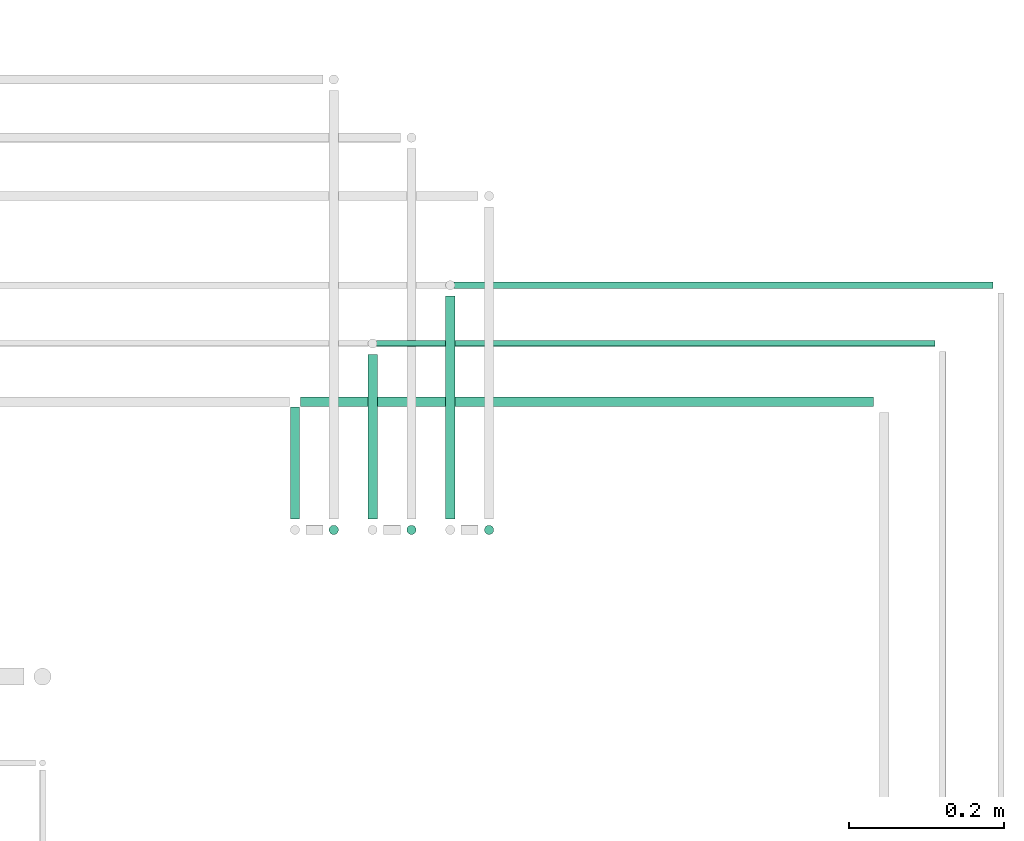
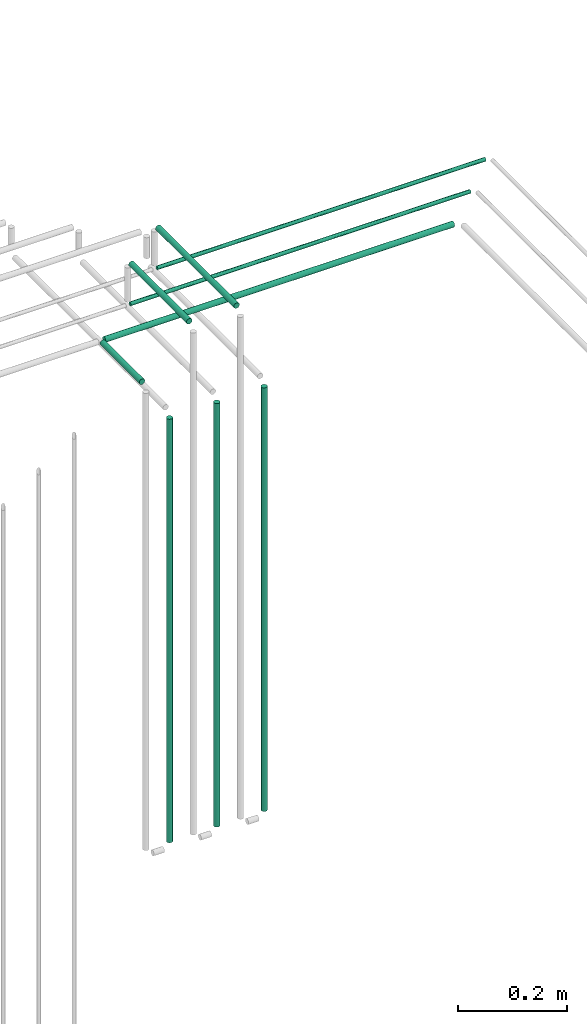
# One storey, part 237 of 331: 9 flow segments.
"""IFC2X3 building model written with IfcOpenShell, lengths in millimetres."""

from ifc_helpers import new_model, entity, si_unit, converted_unit, derived_unit, direction, frame, frame_2d, origin, origin_2d_with_axis, place, context, subcontext, project, spatial, circle, extrude, type_object, element, save


model = new_model("IFC2X3")

# Units and contexts
model_context = context("Model", 3, precision=0.01, world=origin(), true_north=direction((6.12303176911189e-17, 1.0)))
body_context = subcontext(model_context, "Body", "Model", "MODEL_VIEW")
ifc_project = project(units=[si_unit("LENGTHUNIT", "METRE", prefix="MILLI"), si_unit("AREAUNIT", "SQUARE_METRE"), si_unit("VOLUMEUNIT", "CUBIC_METRE"), converted_unit("PLANEANGLEUNIT", "DEGREE", entity("IfcRatioMeasure", 0.0174532925199433), si_unit("PLANEANGLEUNIT", "RADIAN"), dimensions=[0, 0, 0, 0, 0, 0, 0]), si_unit("MASSUNIT", "GRAM", prefix="KILO"), derived_unit("MASSDENSITYUNIT", [(si_unit("MASSUNIT", "GRAM", prefix="KILO"), 1), (si_unit("LENGTHUNIT", "METRE"), -3)]), derived_unit("MOMENTOFINERTIAUNIT", [(si_unit("LENGTHUNIT", "METRE"), 4)]), si_unit("TIMEUNIT", "SECOND"), si_unit("FREQUENCYUNIT", "HERTZ"), si_unit("THERMODYNAMICTEMPERATUREUNIT", "DEGREE_CELSIUS"), derived_unit("THERMALTRANSMITTANCEUNIT", [(si_unit("MASSUNIT", "GRAM", prefix="KILO"), 1), (si_unit("THERMODYNAMICTEMPERATUREUNIT", "KELVIN"), -1), (si_unit("TIMEUNIT", "SECOND"), -3)]), derived_unit("VOLUMETRICFLOWRATEUNIT", [(si_unit("LENGTHUNIT", "METRE"), 3), (si_unit("TIMEUNIT", "SECOND"), -1)]), derived_unit("MASSFLOWRATEUNIT", [(si_unit("MASSUNIT", "GRAM", prefix="KILO"), 1), (si_unit("TIMEUNIT", "SECOND"), -1)]), derived_unit("ROTATIONALFREQUENCYUNIT", [(si_unit("TIMEUNIT", "SECOND"), -1)]), si_unit("ELECTRICCURRENTUNIT", "AMPERE"), si_unit("ELECTRICVOLTAGEUNIT", "VOLT"), si_unit("POWERUNIT", "WATT"), si_unit("FORCEUNIT", "NEWTON", prefix="KILO"), si_unit("ILLUMINANCEUNIT", "LUX"), si_unit("LUMINOUSFLUXUNIT", "LUMEN"), si_unit("LUMINOUSINTENSITYUNIT", "CANDELA"), derived_unit("USERDEFINED", [(si_unit("MASSUNIT", "GRAM", prefix="KILO"), -1), (si_unit("LENGTHUNIT", "METRE"), -2), (si_unit("TIMEUNIT", "SECOND"), 3), (si_unit("LUMINOUSFLUXUNIT", "LUMEN"), 1)]), derived_unit("LINEARVELOCITYUNIT", [(si_unit("LENGTHUNIT", "METRE"), 1), (si_unit("TIMEUNIT", "SECOND"), -1)]), si_unit("PRESSUREUNIT", "PASCAL"), derived_unit("USERDEFINED", [(si_unit("LENGTHUNIT", "METRE"), -2), (si_unit("MASSUNIT", "GRAM", prefix="KILO"), 1), (si_unit("TIMEUNIT", "SECOND"), -2)]), derived_unit("LINEARFORCEUNIT", [(si_unit("MASSUNIT", "GRAM", prefix="KILO"), 1), (si_unit("LENGTHUNIT", "METRE"), 1), (si_unit("TIMEUNIT", "SECOND"), -2), (si_unit("LENGTHUNIT", "METRE"), -1)]), derived_unit("PLANARFORCEUNIT", [(si_unit("MASSUNIT", "GRAM", prefix="KILO"), 1), (si_unit("LENGTHUNIT", "METRE"), 1), (si_unit("TIMEUNIT", "SECOND"), -2), (si_unit("LENGTHUNIT", "METRE"), -2)])], contexts=[model_context])

# Site, building, storey
site_placement = place(None, frame((0.0, -0.00077364408347762, 0.0)))
site = spatial("IfcSite", under=ifc_project, at=site_placement, CompositionType="ELEMENT")
building_placement = place(site_placement, origin())
building = spatial("IfcBuilding", under=site, at=building_placement, CompositionType="ELEMENT")
storey_placement = place(building_placement, origin())
storey = spatial("IfcBuildingStorey", under=building, at=storey_placement, CompositionType="ELEMENT", Elevation=0.0)

# Flow segments
pipe_segment_type = type_object("IfcPipeSegmentType", PredefinedType="NOTDEFINED")
for number, where in (
    (1, (67302.5166110417, 8442.40464384074, 5714.0)),
    (2, (67402.5166110417, 8442.40464384074, 5714.0)),
    (3, (67502.5166110417, 8442.40464384074, 5714.0)),
):
    element("IfcFlowSegment", number, at=place(building_placement, frame(where)), inside=storey, type_object=pipe_segment_type, context=body_context, shape_type="SweptSolid", body=[
        extrude(circle(Radius=6.0, at=frame_2d((0.0, -1.08286712929839e-12), x_axis=(1.0, 0.0))), frame((7.59527223591454, 7.5952722359167, 0.0)), (0.0, 0.0, 1.0), 947.000000000008),
    ])
flow_segment_1_placement = place(building_placement, frame((67252.5166110417, 8463.99991607666, 6742.40472776409)))
element("IfcFlowSegment", 4, at=flow_segment_1_placement, inside=storey, type_object=pipe_segment_type, context=body_context, shape_type="SweptSolid", body=[
    extrude(circle(Radius=6.0, at=frame_2d((0.0, -1.08286712929839e-12), x_axis=(1.0, 0.0))), frame((7.59527223591454, 0.0, 7.5952722359167), z_axis=(0.0, 1.0, 0.0), x_axis=(-1.0, 0.0, 0.0)), (0.0, 0.0, 1.0), 144.000149566779),
])
flow_segment_2_placement = place(storey_placement, frame((67267.1118832777, 8607.40479340752, 6742.40472776408)))
element("IfcFlowSegment", 5, at=flow_segment_2_placement, inside=storey, type_object=pipe_segment_type, context=body_context, shape_type="SweptSolid", body=[
    extrude(circle(Radius=6.0, at=frame_2d((4.33146851719357e-12, -1.08286712929839e-12), x_axis=(1.0, 0.0))), frame((0.0, 7.59527223591995, 7.5952722359167), z_axis=(1.0, 0.0, 0.0), x_axis=(0.0, 1.0, 0.0)), (0.0, 0.0, 1.0), 738.006594217419),
])
flow_segment_3_placement = place(building_placement, frame((67352.5166110417, 8463.99991607666, 6842.4047277641)))
element("IfcFlowSegment", 6, at=flow_segment_3_placement, inside=storey, type_object=pipe_segment_type, context=body_context, shape_type="SweptSolid", body=[
    extrude(circle(Radius=6.0, at=origin_2d_with_axis()), frame((7.59527223591454, 0.0, 7.59527223591562), z_axis=(0.0, 1.0, 0.0), x_axis=(-1.0, 0.0, 0.0)), (0.0, 0.0, 1.0), 212.000149566791),
])
flow_segment_4_placement = place(storey_placement, frame((67365.1118832777, 8684.40479340753, 6744.40472776408)))
element("IfcFlowSegment", 7, at=flow_segment_4_placement, inside=storey, type_object=pipe_segment_type, context=body_context, shape_type="SweptSolid", body=[
    extrude(circle(Radius=4.0, at=origin_2d_with_axis()), frame((0.0, 5.59527223591824, 5.59527223591607), z_axis=(1.0, 0.0, 0.0), x_axis=(0.0, 1.0, 0.0)), (0.0, 0.0, 1.0), 719.006594217423),
])
flow_segment_5_placement = place(building_placement, frame((67452.5166110417, 8463.99991607666, 6842.4047277641)))
element("IfcFlowSegment", 8, at=flow_segment_5_placement, inside=storey, type_object=pipe_segment_type, context=body_context, shape_type="SweptSolid", body=[
    extrude(circle(Radius=6.0, at=origin_2d_with_axis()), frame((7.59527223591454, 0.0, 7.59527223591562), z_axis=(0.0, 1.0, 0.0), x_axis=(-1.0, 0.0, 0.0)), (0.0, 0.0, 1.0), 287.000149566792),
])
flow_segment_6_placement = place(storey_placement, frame((67465.1118832777, 8759.40479340752, 6744.40472776408)))
element("IfcFlowSegment", 9, at=flow_segment_6_placement, inside=storey, type_object=pipe_segment_type, context=body_context, shape_type="SweptSolid", body=[
    extrude(circle(Radius=4.0, at=frame_2d((0.0, 1.08286712929839e-12), x_axis=(1.0, 0.0))), frame((0.0, 5.59527223591607, 5.59527223591607), z_axis=(1.0, 0.0, 0.0), x_axis=(0.0, 1.0, 0.0)), (0.0, 0.0, 1.0), 694.00659421742),
])

save(model, "model.ifc")
